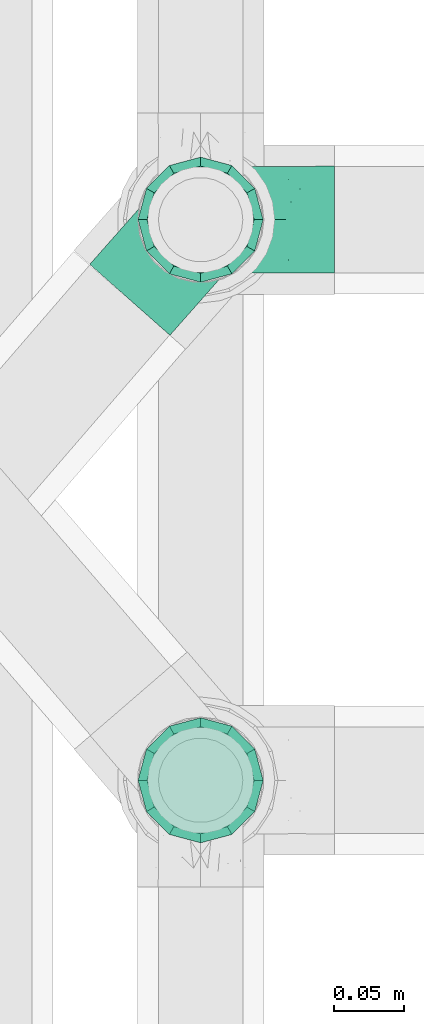
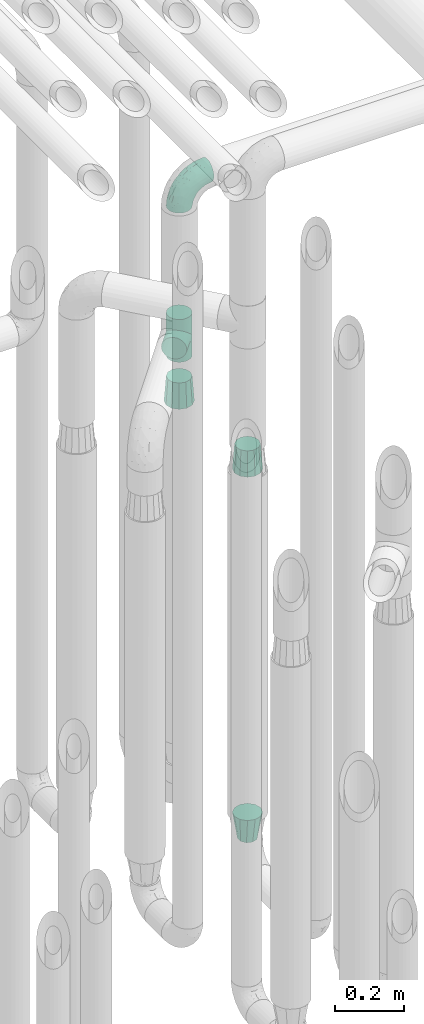
# One storey, part 625 of 824: 5 flow fittings.
"""IFC2X3 building model written with IfcOpenShell, lengths in millimetres."""

from ifc_helpers import new_model, entity, si_unit, converted_unit, derived_unit, direction, frame, origin, place, context, subcontext, project, spatial, faceted_brep, source, transform, mapped, material, type_object, type_shapes, element, save


model = new_model("IFC2X3")

# Units and contexts
model_context = context("Model", 3, precision=0.01, world=origin(), true_north=direction((6.12303176911189e-17, 1.0)))
body_context = subcontext(model_context, "Body", "Model", "MODEL_VIEW")
ifc_project = project(units=[si_unit("LENGTHUNIT", "METRE", prefix="MILLI"), si_unit("AREAUNIT", "SQUARE_METRE"), si_unit("VOLUMEUNIT", "CUBIC_METRE"), converted_unit("PLANEANGLEUNIT", "DEGREE", entity("IfcRatioMeasure", 0.0174532925199433), si_unit("PLANEANGLEUNIT", "RADIAN"), dimensions=[0, 0, 0, 0, 0, 0, 0]), si_unit("MASSUNIT", "GRAM", prefix="KILO"), derived_unit("MASSDENSITYUNIT", [(si_unit("MASSUNIT", "GRAM", prefix="KILO"), 1), (si_unit("LENGTHUNIT", "METRE"), -3)]), derived_unit("MOMENTOFINERTIAUNIT", [(si_unit("LENGTHUNIT", "METRE"), 4)]), si_unit("TIMEUNIT", "SECOND"), si_unit("FREQUENCYUNIT", "HERTZ"), si_unit("THERMODYNAMICTEMPERATUREUNIT", "DEGREE_CELSIUS"), derived_unit("THERMALTRANSMITTANCEUNIT", [(si_unit("MASSUNIT", "GRAM", prefix="KILO"), 1), (si_unit("THERMODYNAMICTEMPERATUREUNIT", "KELVIN"), -1), (si_unit("TIMEUNIT", "SECOND"), -3)]), derived_unit("VOLUMETRICFLOWRATEUNIT", [(si_unit("LENGTHUNIT", "METRE"), 3), (si_unit("TIMEUNIT", "SECOND"), -1)]), derived_unit("MASSFLOWRATEUNIT", [(si_unit("MASSUNIT", "GRAM", prefix="KILO"), 1), (si_unit("TIMEUNIT", "SECOND"), -1)]), derived_unit("ROTATIONALFREQUENCYUNIT", [(si_unit("TIMEUNIT", "SECOND"), -1)]), si_unit("ELECTRICCURRENTUNIT", "AMPERE"), si_unit("ELECTRICVOLTAGEUNIT", "VOLT"), si_unit("POWERUNIT", "WATT"), si_unit("FORCEUNIT", "NEWTON", prefix="KILO"), si_unit("ILLUMINANCEUNIT", "LUX"), si_unit("LUMINOUSFLUXUNIT", "LUMEN"), si_unit("LUMINOUSINTENSITYUNIT", "CANDELA"), derived_unit("USERDEFINED", [(si_unit("MASSUNIT", "GRAM", prefix="KILO"), -1), (si_unit("LENGTHUNIT", "METRE"), -2), (si_unit("TIMEUNIT", "SECOND"), 3), (si_unit("LUMINOUSFLUXUNIT", "LUMEN"), 1)]), derived_unit("LINEARVELOCITYUNIT", [(si_unit("LENGTHUNIT", "METRE"), 1), (si_unit("TIMEUNIT", "SECOND"), -1)]), si_unit("PRESSUREUNIT", "PASCAL"), derived_unit("USERDEFINED", [(si_unit("LENGTHUNIT", "METRE"), -2), (si_unit("MASSUNIT", "GRAM", prefix="KILO"), 1), (si_unit("TIMEUNIT", "SECOND"), -2)]), derived_unit("LINEARFORCEUNIT", [(si_unit("MASSUNIT", "GRAM", prefix="KILO"), 1), (si_unit("LENGTHUNIT", "METRE"), 1), (si_unit("TIMEUNIT", "SECOND"), -2), (si_unit("LENGTHUNIT", "METRE"), -1)]), derived_unit("PLANARFORCEUNIT", [(si_unit("MASSUNIT", "GRAM", prefix="KILO"), 1), (si_unit("LENGTHUNIT", "METRE"), 1), (si_unit("TIMEUNIT", "SECOND"), -2), (si_unit("LENGTHUNIT", "METRE"), -2)])], contexts=[model_context])

# Site, building, storey
site_placement = place(None, origin())
site = spatial("IfcSite", under=ifc_project, at=site_placement, CompositionType="ELEMENT")
building_placement = place(site_placement, origin())
building = spatial("IfcBuilding", under=site, at=building_placement, CompositionType="ELEMENT")
storey_placement = place(building_placement, frame((0.0, 0.0, 28200.0)))
storey = spatial("IfcBuildingStorey", under=building, at=storey_placement, CompositionType="ELEMENT", Elevation=28200.0)

# Flow fittings
ifc_material = material()
pipe_fitting_type_1 = type_object("IfcPipeFittingType", PredefinedType="NOTDEFINED", material=ifc_material)
shared_shape_1 = source(origin(), body_context, "Body", "Brep", [
    faceted_brep([(-95.0, 19.02, -32.95), (-95.0, 9.85, -36.75), (-95.0, 0.0, -38.05), (-95.0, -9.85, -36.75), (-95.0, -19.03, -32.95), (-95.0, -26.91, -26.91), (-95.0, -32.95, -19.03), (-95.0, -36.75, -9.85), (-95.0, -38.05, 0.0), (-95.0, -36.75, 9.85), (-95.0, -32.95, 19.02), (-95.0, -26.91, 26.91), (-95.0, -19.03, 32.95), (-95.0, -9.85, 36.75), (-95.0, 0.0, 38.05), (-95.0, 9.85, 36.75), (-95.0, 19.02, 32.95), (-95.0, 26.91, 26.91), (-95.0, 32.95, 19.02), (-95.0, 36.75, 9.85), (-95.0, 38.05, 0.0), (-95.0, 36.75, -9.85), (-95.0, 32.95, -19.03), (-95.0, 26.91, -26.91), (0.0, 95.0, -38.05), (-9.85, 95.0, -36.75), (-19.02, 95.0, -32.95), (-26.91, 95.0, -26.91), (-32.95, 95.0, -19.03), (-36.75, 95.0, -9.85), (-38.05, 95.0, 0.0), (-36.75, 95.0, 9.85), (-32.95, 95.0, 19.02), (-26.91, 95.0, 26.91), (-19.02, 95.0, 32.95), (-9.85, 95.0, 36.75), (0.0, 95.0, 38.05), (9.85, 95.0, 36.75), (19.03, 95.0, 32.95), (26.91, 95.0, 26.91), (32.95, 95.0, 19.02), (36.75, 95.0, 9.85), (38.05, 95.0, 0.0), (36.75, 95.0, -9.85), (32.95, 95.0, -19.03), (26.91, 95.0, -26.91), (19.03, 95.0, -32.95), (9.85, 95.0, -36.75), (-7.99, -4.96, 6.3), (-0.92, 0.92, 0.0), (4.62, 8.1, 8.01), (-76.19, -35.57, 0.0), (-64.32, -32.32, 12.43), (20.51, 62.45, 28.68), (-60.56, -33.52, 0.0), (-70.4, -13.47, 34.42), (-39.61, -5.88, 32.32), (-49.6, 2.07, 37.1), (-70.34, -28.81, 21.71), (14.64, 40.81, 26.5), (5.88, 39.61, 32.32), (3.59, 20.77, 25.31), (-40.45, 68.06, 16.75), (-62.45, -20.51, 28.68), (-44.52, -26.87, 0.0), (-28.47, -20.22, 0.0), (-26.43, -17.83, 8.75), (-76.1, 39.63, 10.76), (-72.74, 37.58, 18.19), (-60.35, 46.18, 14.61), (-13.4, 13.4, 32.12), (-20.77, -3.59, 25.31), (-14.66, 81.47, 35.56), (-6.22, 71.26, 37.92), (-57.5, 42.48, 22.79), (-15.0, 34.74, 37.7), (-27.1, 12.08, 36.05), (-9.2, 28.81, 35.63), (-79.98, 23.7, 30.95), (-73.68, -4.3, 37.48), (-30.74, 21.67, 37.97), (-62.36, 47.59, 6.79), (-72.71, 32.83, 24.69), (-67.42, 7.02, 37.95), (-32.13, 75.27, 24.51), (-43.46, 51.47, 26.26), (-24.98, 73.15, 31.29), (20.59, 41.28, 19.85), (7.79, 16.09, 15.86), (-73.21, 42.39, 0.0), (-54.73, 54.73, 0.0), (-73.44, 15.79, 35.79), (-5.94, 4.32, 20.43), (28.81, 70.34, 21.71), (32.32, 64.32, 12.43), (-53.59, 26.2, 35.09), (-52.02, 19.31, 37.21), (21.38, 33.53, 10.34), (26.87, 44.52, 0.0), (-48.28, 12.14, 38.05), (4.3, 73.68, 37.48), (-44.08, -25.52, 12.79), (-41.28, -20.59, 19.85), (35.57, 76.19, 0.0), (-47.26, 54.3, 20.18), (-47.4, 61.99, 8.58), (-42.39, 73.21, 0.0), (-39.67, 78.86, 7.21), (-45.69, 36.84, 33.11), (-32.83, 50.13, 33.35), (13.47, 70.4, 34.42), (-18.25, 63.73, 36.07), (-40.63, -13.75, 27.22), (-16.63, 46.37, 37.95), (-53.47, 38.79, 28.59), (-26.07, 48.54, 36.15), (-34.51, 34.51, 36.86), (-2.07, 49.6, 37.1), (-22.79, -10.49, 19.23), (-61.73, 28.67, 31.87), (9.65, 14.7, 0.0), (20.22, 28.47, 0.0), (33.52, 60.56, 0.0), (-11.42, -5.44, 13.25), (-14.7, -9.65, 0.0), (-81.47, 14.66, -35.56), (-62.45, -20.51, -28.68), (-71.26, 6.22, -37.92), (-75.27, 32.13, -24.51), (-73.15, 24.98, -31.29), (13.47, 70.4, -34.42), (5.88, 39.61, -32.32), (-2.07, 49.6, -37.1), (-78.86, 39.67, -7.21), (-70.4, -13.47, -34.42), (-39.61, -5.88, -32.32), (-61.99, 47.4, -8.58), (32.32, 64.32, -12.43), (28.81, 70.34, -21.71), (-63.73, 18.25, -36.07), (-50.13, 32.83, -33.35), (4.3, 73.68, -37.48), (-7.02, 67.42, -37.95), (-39.63, 76.1, -10.76), (-46.18, 60.35, -14.61), (-47.59, 62.36, -6.79), (-64.32, -32.32, -12.43), (-26.2, 53.59, -35.09), (-15.79, 73.44, -35.79), (-19.31, 52.02, -37.21), (-37.58, 72.74, -18.19), (-70.34, -28.81, -21.71), (-42.48, 57.5, -22.79), (-38.79, 53.47, -28.59), (-51.47, 43.46, -26.26), (-32.83, 72.71, -24.69), (-46.37, 16.63, -37.95), (-73.68, -4.3, -37.48), (-41.28, -20.59, -19.85), (-44.08, -25.52, -12.79), (13.75, 40.63, -27.22), (20.51, 62.45, -28.68), (-68.06, 40.45, -16.75), (-54.3, 47.26, -20.18), (-12.14, 48.28, -38.05), (-21.67, 30.74, -37.97), (-36.84, 45.69, -33.11), (-11.42, -5.44, -13.25), (7.79, 16.09, -15.86), (4.62, 8.1, -8.01), (-23.7, 79.98, -30.95), (-26.43, -17.83, -8.75), (-7.99, -4.96, -6.3), (-40.81, -14.64, -26.5), (-20.77, -3.59, -25.31), (-34.74, 15.0, -37.7), (-12.08, 27.1, -36.05), (-28.81, 9.2, -35.63), (-22.79, -10.49, -19.23), (21.38, 33.53, -10.34), (20.59, 41.28, -19.85), (-48.54, 26.07, -36.15), (-49.6, 2.07, -37.1), (-13.4, 13.4, -32.12), (3.59, 20.77, -25.31), (-28.67, 61.73, -31.87), (-34.51, 34.51, -36.86), (-5.94, 4.32, -20.43)], [[[0, 1, 2, 3, 4, 5, 6, 7, 8, 9, 10, 11, 12, 13, 14, 15, 16, 17, 18, 19, 20, 21, 22, 23]], [[24, 25, 26, 27, 28, 29, 30, 31, 32, 33, 34, 35, 36, 37, 38, 39, 40, 41, 42, 43, 44, 45, 46, 47]], [[48, 49, 50]], [[51, 52, 9]], [[53, 39, 38]], [[9, 52, 10]], [[54, 52, 51]], [[55, 56, 57]], [[11, 10, 58]], [[59, 60, 61]], [[32, 31, 62]], [[63, 12, 11]], [[63, 55, 12]], [[64, 65, 66]], [[67, 68, 69]], [[70, 56, 71]], [[35, 72, 73]], [[69, 68, 74]], [[75, 76, 77]], [[16, 78, 17]], [[13, 79, 14]], [[76, 75, 80]], [[67, 69, 81]], [[18, 17, 82]], [[14, 79, 83]], [[20, 19, 67]], [[84, 85, 86]], [[87, 61, 88]], [[89, 81, 90]], [[18, 82, 68]], [[15, 91, 16]], [[14, 83, 15]], [[71, 92, 61]], [[17, 78, 82]], [[93, 87, 94]], [[95, 91, 96]], [[97, 98, 94]], [[86, 72, 34]], [[96, 99, 80]], [[37, 36, 100]], [[40, 39, 93]], [[40, 94, 41]], [[64, 66, 101]], [[93, 94, 40]], [[58, 102, 63]], [[94, 103, 41]], [[94, 87, 97]], [[104, 69, 74]], [[34, 33, 86]], [[105, 69, 104]], [[52, 58, 10]], [[106, 107, 30]], [[108, 109, 85]], [[105, 106, 90]], [[53, 110, 60]], [[86, 111, 72]], [[86, 109, 111]], [[33, 84, 86]], [[12, 55, 13]], [[112, 56, 63]], [[110, 38, 37]], [[34, 72, 35]], [[36, 35, 73]], [[111, 113, 73]], [[105, 107, 106]], [[110, 53, 38]], [[74, 114, 85]], [[91, 15, 83]], [[105, 90, 81]], [[107, 62, 31]], [[33, 32, 84]], [[115, 109, 116]], [[111, 115, 113]], [[100, 73, 117]], [[56, 55, 63]], [[79, 55, 57]], [[102, 118, 112]], [[56, 70, 76]], [[100, 110, 37]], [[117, 77, 60]], [[117, 60, 110]], [[60, 70, 61]], [[58, 52, 101]], [[63, 11, 58]], [[39, 53, 93]], [[87, 93, 53]], [[96, 91, 83]], [[78, 91, 119]], [[32, 62, 84]], [[84, 62, 104]], [[86, 85, 109]], [[85, 114, 108]], [[80, 113, 116]], [[117, 73, 113]], [[80, 116, 96]], [[80, 57, 76]], [[71, 112, 118]], [[61, 87, 59]], [[62, 107, 105]], [[97, 120, 121]], [[70, 71, 61]], [[71, 118, 92]], [[73, 100, 36]], [[110, 100, 117]], [[55, 79, 13]], [[83, 79, 57]], [[96, 83, 99]], [[116, 108, 95]], [[50, 97, 88]], [[97, 87, 88]], [[50, 49, 120]], [[122, 94, 98]], [[89, 20, 67]], [[105, 81, 69]], [[89, 67, 81]], [[68, 19, 18]], [[68, 67, 19]], [[74, 68, 82]], [[114, 82, 119]], [[74, 85, 104]], [[82, 114, 74]], [[114, 119, 108]], [[95, 108, 119]], [[116, 109, 108]], [[123, 48, 50]], [[97, 50, 120]], [[123, 50, 88]], [[91, 95, 119]], [[116, 95, 96]], [[84, 104, 85]], [[104, 62, 105]], [[83, 57, 99]], [[57, 80, 99]], [[66, 48, 123]], [[66, 124, 48]], [[118, 66, 123]], [[124, 66, 65]], [[66, 118, 101]], [[54, 64, 52]], [[124, 49, 48]], [[30, 107, 31]], [[91, 78, 16]], [[82, 78, 119]], [[56, 76, 57]], [[77, 76, 70]], [[60, 77, 70]], [[77, 117, 75]], [[117, 113, 75]], [[113, 80, 75]], [[9, 8, 51]], [[103, 94, 122]], [[103, 42, 41]], [[73, 72, 111]], [[113, 115, 116]], [[111, 109, 115]], [[102, 112, 63]], [[71, 56, 112]], [[118, 102, 101]], [[92, 123, 88]], [[123, 92, 118]], [[61, 92, 88]], [[87, 53, 59]], [[60, 59, 53]], [[97, 121, 98]], [[58, 101, 102]], [[64, 101, 52]], [[125, 1, 0]], [[126, 5, 4]], [[2, 1, 127]], [[1, 125, 127]], [[128, 129, 23]], [[130, 131, 132]], [[89, 133, 20]], [[126, 134, 135]], [[136, 89, 90]], [[137, 138, 44]], [[139, 129, 140]], [[24, 141, 142]], [[143, 144, 145]], [[125, 129, 139]], [[6, 146, 7]], [[147, 148, 149]], [[146, 51, 7]], [[143, 150, 144]], [[146, 6, 151]], [[152, 153, 154]], [[126, 4, 134]], [[0, 23, 129]], [[28, 155, 150]], [[43, 42, 103]], [[54, 146, 64]], [[139, 156, 127]], [[157, 3, 2]], [[151, 158, 159]], [[160, 131, 161]], [[22, 21, 162]], [[136, 144, 163]], [[149, 164, 165]], [[24, 142, 25]], [[166, 140, 154]], [[154, 129, 128]], [[143, 30, 29]], [[167, 168, 169]], [[155, 28, 27]], [[26, 170, 27]], [[171, 167, 172]], [[26, 25, 148]], [[27, 170, 155]], [[173, 135, 174]], [[144, 150, 152]], [[175, 176, 177]], [[24, 47, 141]], [[45, 161, 46]], [[148, 25, 142]], [[176, 175, 165]], [[64, 159, 171]], [[138, 45, 44]], [[130, 46, 161]], [[137, 44, 43]], [[178, 159, 158]], [[137, 103, 122]], [[163, 144, 152]], [[136, 133, 89]], [[103, 137, 43]], [[6, 5, 151]], [[178, 158, 173]], [[134, 4, 3]], [[178, 173, 174]], [[137, 98, 179]], [[145, 90, 106]], [[138, 180, 161]], [[46, 130, 47]], [[136, 90, 145]], [[133, 162, 21]], [[23, 22, 128]], [[139, 140, 181]], [[139, 181, 156]], [[157, 127, 182]], [[157, 134, 3]], [[182, 177, 135]], [[182, 135, 134]], [[135, 183, 174]], [[131, 130, 161]], [[141, 130, 132]], [[160, 180, 184]], [[131, 183, 176]], [[5, 126, 151]], [[158, 151, 126]], [[180, 138, 137]], [[161, 45, 138]], [[149, 148, 142]], [[170, 148, 185]], [[22, 162, 128]], [[128, 162, 163]], [[129, 154, 140]], [[154, 153, 166]], [[165, 156, 186]], [[182, 127, 156]], [[165, 186, 149]], [[165, 132, 176]], [[131, 184, 183]], [[187, 167, 178]], [[184, 168, 187]], [[167, 169, 172]], [[184, 180, 168]], [[174, 183, 184]], [[127, 157, 2]], [[134, 157, 182]], [[130, 141, 47]], [[142, 141, 132]], [[149, 142, 164]], [[186, 166, 147]], [[180, 179, 168]], [[169, 179, 120]], [[137, 179, 180]], [[179, 121, 120]], [[106, 30, 143]], [[136, 145, 144]], [[106, 143, 145]], [[150, 29, 28]], [[150, 143, 29]], [[152, 150, 155]], [[153, 155, 185]], [[152, 154, 163]], [[155, 153, 152]], [[153, 185, 166]], [[147, 166, 185]], [[186, 140, 166]], [[169, 120, 49]], [[169, 49, 172]], [[179, 169, 168]], [[148, 147, 185]], [[186, 147, 149]], [[128, 163, 154]], [[163, 162, 136]], [[142, 132, 164]], [[132, 165, 164]], [[171, 124, 65]], [[124, 171, 172]], [[64, 146, 159]], [[171, 159, 178]], [[171, 65, 64]], [[172, 49, 124]], [[162, 133, 136]], [[20, 133, 21]], [[148, 170, 26]], [[155, 170, 185]], [[131, 176, 132]], [[177, 176, 183]], [[135, 177, 183]], [[177, 182, 175]], [[182, 156, 175]], [[156, 165, 175]], [[51, 146, 54]], [[51, 8, 7]], [[129, 125, 0]], [[127, 125, 139]], [[140, 186, 181]], [[156, 181, 186]], [[158, 126, 173]], [[135, 173, 126]], [[187, 178, 174]], [[171, 178, 167]], [[184, 187, 174]], [[167, 187, 168]], [[180, 160, 161]], [[184, 131, 160]], [[98, 137, 122]], [[98, 121, 179]], [[151, 159, 146]]]),
])
type_shapes(pipe_fitting_type_1, [shared_shape_1])
flow_fitting_1_placement = place(storey_placement, frame((36975.03, 12979.64, 2600.0), z_axis=(0.0, 1.0, 0.0), x_axis=(0.0, 0.0, 1.0)))
element("IfcFlowFitting", 1, at=flow_fitting_1_placement, inside=storey, type_object=pipe_fitting_type_1, material=ifc_material, context=body_context, shape_type="MappedRepresentation", body=[
    mapped(shared_shape_1, transform((0.0, 0.0, 0.0), scale=1.0)),
])
pipe_fitting_type_2 = type_object("IfcPipeFittingType", PredefinedType="NOTDEFINED", material=ifc_material)
shared_shape_2 = source(origin(), body_context, "Body", "Brep", [
    faceted_brep([(-76.0, 9.85, -36.75), (-76.0, 0.0, -38.05), (-76.0, -9.85, -36.75), (-76.0, -19.03, -32.95), (-76.0, -22.97, -29.93), (-76.0, -26.91, -26.91), (-76.0, -29.93, -22.97), (-76.0, -32.95, -19.03), (-76.0, -34.85, -14.44), (-76.0, -36.75, -9.85), (-76.0, -38.05, 0.0), (-76.0, -36.75, 9.85), (-76.0, -34.85, 14.44), (-76.0, -32.95, 19.02), (-76.0, -29.93, 22.97), (-76.0, -26.91, 26.91), (-76.0, -22.97, 29.93), (-76.0, -19.03, 32.95), (-76.0, -9.85, 36.75), (-76.0, 0.0, 38.05), (-76.0, 9.85, 36.75), (-76.0, 19.02, 32.95), (-76.0, 26.91, 26.91), (-76.0, 32.95, 19.02), (-76.0, 36.75, 9.85), (-76.0, 38.05, 0.0), (-76.0, 36.75, -9.85), (-76.0, 32.95, -19.03), (-76.0, 26.91, -26.91), (-76.0, 19.02, -32.95), (76.0, 26.91, -26.91), (76.0, 32.95, -19.03), (76.0, 36.75, -9.85), (76.0, 38.05, 0.0), (76.0, 36.75, 9.85), (76.0, 32.95, 19.02), (76.0, 26.91, 26.91), (76.0, 19.02, 32.95), (76.0, 9.85, 36.75), (76.0, 0.0, 38.05), (76.0, -9.85, 36.75), (76.0, -19.03, 32.95), (76.0, -22.97, 29.93), (76.0, -26.91, 26.91), (76.0, -29.93, 22.97), (76.0, -32.95, 19.02), (76.0, -34.85, 14.44), (76.0, -36.75, 9.85), (76.0, -38.05, 0.0), (76.0, -36.75, -9.85), (76.0, -34.85, -14.44), (76.0, -32.95, -19.03), (76.0, -29.93, -22.97), (76.0, -26.91, -26.91), (76.0, -22.97, -29.93), (76.0, -19.03, -32.95), (76.0, -9.85, -36.75), (76.0, 0.0, -38.05), (76.0, 9.85, -36.75), (76.0, 19.02, -32.95), (36.99, -36.99, 8.94), (38.05, -38.05, 0.0), (-36.99, -36.99, 8.94), (-38.05, -38.05, 0.0), (35.51, -35.51, 12.97), (34.04, -34.04, 17.0), (18.81, -18.81, 33.08), (29.74, -29.74, 23.73), (24.56, -24.56, 29.06), (-35.51, -35.51, 12.97), (-34.04, -34.04, 17.0), (-18.81, -18.81, 33.08), (-29.74, -29.74, 23.73), (-24.56, -24.56, 29.06), (-12.7, -12.7, 35.87), (6.4, -6.4, 37.51), (12.7, -12.7, 35.87), (0.0, 0.0, 38.05), (-6.4, -6.4, 37.51), (6.4, -6.4, -37.51), (0.0, 0.0, -38.05), (12.7, -12.7, -35.87), (-24.56, -24.56, -29.06), (-6.4, -6.4, -37.51), (-35.51, -35.51, -12.97), (-36.99, -36.99, -8.94), (-29.74, -29.74, -23.73), (-12.7, -12.7, -35.87), (18.81, -18.81, -33.08), (24.56, -24.56, -29.06), (-34.04, -34.04, -17.0), (29.74, -29.74, -23.73), (36.99, -36.99, -8.94), (35.51, -35.51, -12.97), (34.04, -34.04, -17.0), (-18.81, -18.81, -33.08), (9.85, -76.0, -36.75), (19.03, -76.0, -32.95), (26.91, -76.0, -26.91), (32.95, -76.0, -19.03), (36.75, -76.0, -9.85), (38.05, -76.0, 0.0), (36.75, -76.0, 9.85), (32.95, -76.0, 19.02), (26.91, -76.0, 26.91), (19.03, -76.0, 32.95), (9.85, -76.0, 36.75), (0.0, -76.0, 38.05), (-9.85, -76.0, 36.75), (-19.02, -76.0, 32.95), (-26.91, -76.0, 26.91), (-32.95, -76.0, 19.02), (-36.75, -76.0, 9.85), (-38.05, -76.0, 0.0), (-36.75, -76.0, -9.85), (-32.95, -76.0, -19.03), (-26.91, -76.0, -26.91), (-19.02, -76.0, -32.95), (-9.85, -76.0, -36.75), (0.0, -76.0, -38.05)], [[[0, 1, 2, 3, 4, 5, 6, 7, 8, 9, 10, 11, 12, 13, 14, 15, 16, 17, 18, 19, 20, 21, 22, 23, 24, 25, 26, 27, 28, 29]], [[30, 31, 32, 33, 34, 35, 36, 37, 38, 39, 40, 41, 42, 43, 44, 45, 46, 47, 48, 49, 50, 51, 52, 53, 54, 55, 56, 57, 58, 59]], [[48, 47, 60]], [[60, 61, 48]], [[62, 10, 63]], [[47, 46, 64]], [[46, 45, 65]], [[41, 66, 42]], [[43, 67, 45, 44]], [[67, 43, 68]], [[45, 67, 65]], [[68, 43, 42]], [[11, 69, 12]], [[70, 12, 69]], [[10, 62, 11]], [[11, 62, 69]], [[71, 17, 16]], [[72, 73, 15]], [[72, 15, 14, 13]], [[15, 73, 16]], [[71, 74, 17]], [[72, 13, 70]], [[46, 65, 64]], [[42, 66, 68]], [[40, 39, 75]], [[47, 64, 60]], [[66, 41, 76]], [[75, 76, 40]], [[75, 39, 77]], [[78, 77, 19]], [[76, 41, 40]], [[23, 22, 36, 35]], [[24, 23, 35, 34]], [[21, 20, 38, 37]], [[22, 21, 37, 36]], [[38, 20, 19, 77, 39]], [[25, 24, 34, 33]], [[70, 13, 12]], [[78, 18, 74]], [[18, 78, 19]], [[18, 17, 74]], [[71, 16, 73]], [[28, 27, 31, 30]], [[26, 32, 31, 27]], [[25, 33, 32, 26]], [[29, 28, 30, 59]], [[57, 56, 79]], [[58, 57, 80, 1, 0]], [[79, 56, 81]], [[82, 5, 4]], [[59, 58, 0, 29]], [[56, 55, 81]], [[57, 79, 80]], [[80, 83, 1]], [[9, 84, 85]], [[86, 7, 6, 5]], [[83, 87, 2]], [[1, 83, 2]], [[87, 3, 2]], [[88, 54, 89]], [[54, 53, 89]], [[8, 90, 84]], [[88, 55, 54]], [[91, 89, 53]], [[52, 51, 91, 53]], [[55, 88, 81]], [[49, 92, 93]], [[92, 49, 48]], [[94, 50, 93]], [[61, 92, 48]], [[85, 63, 10]], [[51, 94, 91]], [[82, 4, 95]], [[49, 93, 50]], [[4, 3, 95]], [[5, 82, 86]], [[94, 51, 50]], [[95, 3, 87]], [[9, 8, 84]], [[90, 8, 7]], [[9, 85, 10]], [[90, 7, 86]], [[96, 97, 98, 99, 100, 101, 102, 103, 104, 105, 106, 107, 108, 109, 110, 111, 112, 113, 114, 115, 116, 117, 118, 119]], [[62, 63, 113]], [[112, 62, 113]], [[110, 109, 73]], [[72, 111, 110]], [[70, 112, 111]], [[74, 109, 108]], [[112, 70, 69, 62]], [[73, 72, 110]], [[70, 111, 72]], [[74, 71, 109]], [[107, 77, 78]], [[74, 108, 78]], [[73, 109, 71]], [[78, 108, 107]], [[75, 107, 106]], [[105, 76, 106]], [[103, 102, 65]], [[67, 104, 103]], [[68, 105, 104]], [[60, 102, 101]], [[68, 66, 105]], [[76, 75, 106]], [[66, 76, 105]], [[61, 60, 101]], [[65, 67, 103]], [[102, 60, 64, 65]], [[68, 104, 67]], [[107, 75, 77]], [[61, 101, 92]], [[100, 92, 101]], [[98, 97, 89]], [[94, 100, 99]], [[98, 91, 99]], [[81, 97, 96]], [[100, 94, 93, 92]], [[89, 91, 98]], [[94, 99, 91]], [[81, 88, 97]], [[119, 80, 79]], [[81, 96, 79]], [[89, 97, 88]], [[79, 96, 119]], [[83, 119, 118]], [[117, 87, 118]], [[115, 114, 90]], [[86, 116, 115]], [[82, 117, 116]], [[85, 114, 113]], [[82, 95, 117]], [[87, 83, 118]], [[95, 87, 117]], [[63, 85, 113]], [[90, 86, 115]], [[114, 85, 84, 90]], [[82, 116, 86]], [[119, 83, 80]]]),
])
type_shapes(pipe_fitting_type_2, [shared_shape_2])
flow_fitting_2_placement = place(storey_placement, frame((36975.03, 12979.64, 2050.0), z_axis=(-0.749374472575658, 0.662146433843719, 0.0), x_axis=(0.0, 0.0, 1.0)))
element("IfcFlowFitting", 2, at=flow_fitting_2_placement, inside=storey, type_object=pipe_fitting_type_2, material=ifc_material, context=body_context, shape_type="MappedRepresentation", body=[
    mapped(shared_shape_2, transform((0.0, 0.0, 0.0), scale=1.0)),
])
pipe_fitting_type_3 = type_object("IfcPipeFittingType", PredefinedType="NOTDEFINED", material=ifc_material)
shared_shape_3 = source(origin(), body_context, "Body", "Brep", [
    faceted_brep([(89.0, -44.45, 0.0), (89.0, -41.96, -9.31), (89.0, -38.49, -22.22), (89.0, -30.36, -30.36), (89.0, -22.23, -38.49), (89.0, -11.11, -41.47), (89.0, 0.0, -44.45), (89.0, 11.11, -41.47), (89.0, 22.22, -38.49), (89.0, 30.36, -30.36), (89.0, 38.49, -22.22), (89.0, 41.96, -9.31), (89.0, 44.45, 0.0), (89.0, 41.96, 9.31), (89.0, 38.49, 22.23), (89.0, 30.36, 30.36), (89.0, 22.22, 38.49), (89.0, 11.11, 41.47), (89.0, 0.0, 44.45), (89.0, -11.11, 41.47), (89.0, -22.23, 38.49), (89.0, -30.36, 30.36), (89.0, -38.49, 22.23), (89.0, -41.96, 9.31), (0.0, 38.05, 0.0), (0.0, 35.5, -9.51), (0.0, 32.95, -19.02), (0.0, 25.99, -25.99), (0.0, 19.02, -32.95), (0.0, 9.51, -35.5), (0.0, 0.0, -38.05), (0.0, -9.51, -35.5), (0.0, -19.03, -32.95), (0.0, -25.99, -25.99), (0.0, -32.95, -19.02), (0.0, -35.5, -9.51), (0.0, -38.05, 0.0), (0.0, -35.5, 9.51), (0.0, -32.95, 19.03), (0.0, -25.99, 25.99), (0.0, -19.03, 32.95), (0.0, -9.51, 35.5), (0.0, 0.0, 38.05), (0.0, 9.51, 35.5), (0.0, 19.03, 32.95), (0.0, 25.99, 25.99), (0.0, 32.95, 19.03), (0.0, 35.5, 9.51)], [[[0, 1, 2, 3, 4, 5, 6, 7, 8, 9, 10, 11, 12, 13, 14, 15, 16, 17, 18, 19, 20, 21, 22, 23]], [[24, 25, 26, 27, 28, 29, 30, 31, 32, 33, 34, 35, 36, 37, 38, 39, 40, 41, 42, 43, 44, 45, 46, 47]], [[2, 1, 0, 36, 35, 34]], [[28, 8, 7, 6, 30, 29]], [[32, 4, 3, 2, 34, 33]], [[5, 4, 32, 31, 30, 6]], [[10, 26, 25, 24, 12, 11]], [[9, 8, 28, 27, 26, 10]], [[14, 13, 12, 24, 47, 46]], [[40, 20, 19, 18, 42, 41]], [[44, 16, 15, 14, 46, 45]], [[17, 16, 44, 43, 42, 18]], [[22, 38, 37, 36, 0, 23]], [[21, 20, 40, 39, 38, 22]]]),
])
type_shapes(pipe_fitting_type_3, [shared_shape_3])
flow_fitting_3_placement = place(storey_placement, frame((36975.03, 12581.17, 1900.0), z_axis=(0.0, 1.0, 0.0), x_axis=(0.0, 0.0, -1.0)))
element("IfcFlowFitting", 3, at=flow_fitting_3_placement, inside=storey, type_object=pipe_fitting_type_3, material=ifc_material, context=body_context, shape_type="MappedRepresentation", body=[
    mapped(shared_shape_3, transform((0.0, 0.0, 0.0), scale=1.0)),
])
pipe_fitting_type_4 = type_object("IfcPipeFittingType", PredefinedType="NOTDEFINED", material=ifc_material)
shared_shape_4 = source(origin(), body_context, "Body", "Brep", [
    faceted_brep([(89.0, -44.45, 0.0), (89.0, -42.1, -8.76), (89.0, -38.49, -22.22), (89.0, -30.36, -30.36), (89.0, -22.23, -38.49), (89.0, -11.11, -41.47), (89.0, 0.0, -44.45), (89.0, 11.11, -41.47), (89.0, 22.22, -38.49), (89.0, 30.36, -30.36), (89.0, 38.49, -22.22), (89.0, 42.1, -8.76), (89.0, 44.45, 0.0), (89.0, 42.1, 8.76), (89.0, 38.49, 22.23), (89.0, 30.36, 30.36), (89.0, 22.22, 38.49), (89.0, 11.11, 41.47), (89.0, 0.0, 44.45), (89.0, -11.11, 41.47), (89.0, -22.23, 38.49), (89.0, -30.36, 30.36), (89.0, -38.49, 22.23), (89.0, -42.1, 8.76), (0.0, 30.15, 0.0), (0.0, 27.27, -8.86), (0.0, 24.39, -17.72), (0.0, 16.85, -23.2), (0.0, 9.32, -28.67), (0.0, 0.0, -28.67), (0.0, -9.32, -28.67), (0.0, -16.85, -23.2), (0.0, -24.39, -17.72), (0.0, -27.27, -8.86), (0.0, -30.15, 0.0), (0.0, -27.27, 8.86), (0.0, -24.39, 17.72), (0.0, -16.85, 23.2), (0.0, -9.32, 28.67), (0.0, 0.0, 28.67), (0.0, 9.32, 28.67), (0.0, 16.85, 23.2), (0.0, 24.39, 17.72), (0.0, 27.27, 8.86)], [[[0, 1, 2, 3, 4, 5, 6, 7, 8, 9, 10, 11, 12, 13, 14, 15, 16, 17, 18, 19, 20, 21, 22, 23]], [[24, 25, 26, 27, 28, 29, 30, 31, 32, 33, 34, 35, 36, 37, 38, 39, 40, 41, 42, 43]], [[2, 33, 32]], [[28, 7, 29]], [[29, 5, 30]], [[24, 12, 11]], [[3, 32, 31]], [[34, 1, 0]], [[1, 34, 33]], [[8, 28, 27]], [[2, 1, 33]], [[31, 4, 3]], [[2, 32, 3]], [[11, 25, 24]], [[26, 10, 9]], [[10, 25, 11]], [[28, 8, 7]], [[27, 26, 9]], [[26, 25, 10]], [[31, 30, 4]], [[8, 27, 9]], [[29, 7, 6]], [[5, 29, 6]], [[5, 4, 30]], [[14, 43, 42]], [[38, 19, 39]], [[39, 17, 40]], [[34, 0, 23]], [[15, 42, 41]], [[24, 13, 12]], [[13, 24, 43]], [[20, 38, 37]], [[14, 13, 43]], [[41, 16, 15]], [[14, 42, 15]], [[23, 35, 34]], [[36, 22, 21]], [[22, 35, 23]], [[38, 20, 19]], [[37, 36, 21]], [[36, 35, 22]], [[41, 40, 16]], [[20, 37, 21]], [[39, 19, 18]], [[17, 39, 18]], [[17, 16, 40]]]),
])
type_shapes(pipe_fitting_type_4, [shared_shape_4])
flow_fitting_4_placement = place(storey_placement, frame((36975.03, 12581.17, 500.0), z_axis=(1.0, 0.0, 0.0), x_axis=(0.0, 0.0, 1.0)))
element("IfcFlowFitting", 4, at=flow_fitting_4_placement, inside=storey, type_object=pipe_fitting_type_4, material=ifc_material, context=body_context, shape_type="MappedRepresentation", body=[
    mapped(shared_shape_4, transform((0.0, 0.0, 0.0), scale=1.0)),
])
pipe_fitting_type_5 = type_object("IfcPipeFittingType", PredefinedType="NOTDEFINED", material=ifc_material)
shared_shape_5 = source(origin(), body_context, "Body", "Brep", [
    faceted_brep([(89.0, 38.05, 0.0), (89.0, 35.5, 9.51), (89.0, 32.95, 19.03), (89.0, 25.99, 25.99), (89.0, 19.02, 32.95), (89.0, 9.51, 35.5), (89.0, 0.0, 38.05), (89.0, -9.51, 35.5), (89.0, -19.03, 32.95), (89.0, -25.99, 25.99), (89.0, -32.95, 19.03), (89.0, -35.5, 9.51), (89.0, -38.05, 0.0), (89.0, -35.5, -9.51), (89.0, -32.95, -19.02), (89.0, -25.99, -25.99), (89.0, -19.03, -32.95), (89.0, -9.51, -35.5), (89.0, 0.0, -38.05), (89.0, 9.51, -35.5), (89.0, 19.02, -32.95), (89.0, 25.99, -25.99), (89.0, 32.95, -19.03), (89.0, 35.5, -9.51), (0.0, -38.49, 22.22), (0.0, -30.36, 30.36), (0.0, -22.22, 38.49), (0.0, -11.11, 41.47), (0.0, 0.0, 44.45), (0.0, 11.11, 41.47), (0.0, 22.23, 38.49), (0.0, 30.36, 30.36), (0.0, 38.49, 22.22), (0.0, 41.96, 9.31), (0.0, 44.45, 0.0), (0.0, 41.47, -11.11), (0.0, 38.49, -22.23), (0.0, 30.36, -30.36), (0.0, 22.23, -38.49), (0.0, 11.11, -41.47), (0.0, 0.0, -44.45), (0.0, -11.11, -41.47), (0.0, -22.23, -38.49), (0.0, -30.36, -30.36), (0.0, -38.49, -22.23), (0.0, -41.96, -9.31), (0.0, -44.45, 0.0), (0.0, -41.47, 11.11)], [[[0, 1, 2, 3, 4, 5, 6, 7, 8, 9, 10, 11, 12, 13, 14, 15, 16, 17, 18, 19, 20, 21, 22, 23]], [[24, 25, 26, 27, 28, 29, 30, 31, 32, 33, 34, 35, 36, 37, 38, 39, 40, 41, 42, 43, 44, 45, 46, 47]], [[23, 22, 36, 35, 34, 0]], [[39, 38, 20, 19, 18, 40]], [[38, 37, 36, 22, 21, 20]], [[43, 42, 16, 15, 14, 44]], [[41, 40, 18, 17, 16, 42]], [[12, 46, 45, 44, 14, 13]], [[11, 10, 24, 47, 46, 12]], [[27, 26, 8, 7, 6, 28]], [[26, 25, 24, 10, 9, 8]], [[31, 30, 4, 3, 2, 32]], [[29, 28, 6, 5, 4, 30]], [[0, 34, 33, 32, 2, 1]]]),
])
type_shapes(pipe_fitting_type_5, [shared_shape_5])
flow_fitting_5_placement = place(storey_placement, frame((36975.03, 12979.64, 1811.0), z_axis=(1.0, 0.0, 0.0), x_axis=(0.0, 0.0, 1.0)))
element("IfcFlowFitting", 5, at=flow_fitting_5_placement, inside=storey, type_object=pipe_fitting_type_5, material=ifc_material, context=body_context, shape_type="MappedRepresentation", body=[
    mapped(shared_shape_5, transform((0.0, 0.0, 0.0), scale=1.0)),
])

save(model, "model.ifc")
